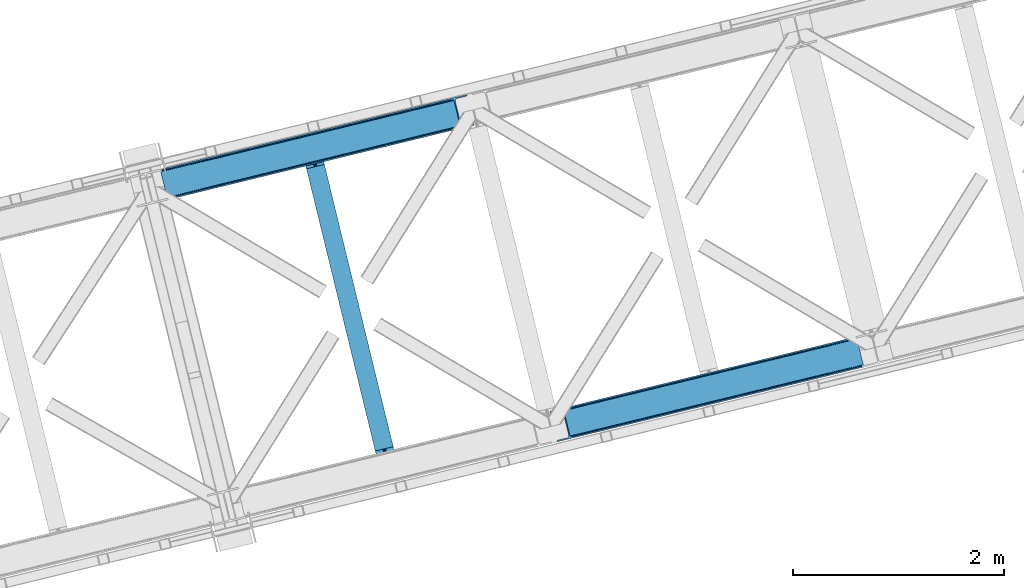
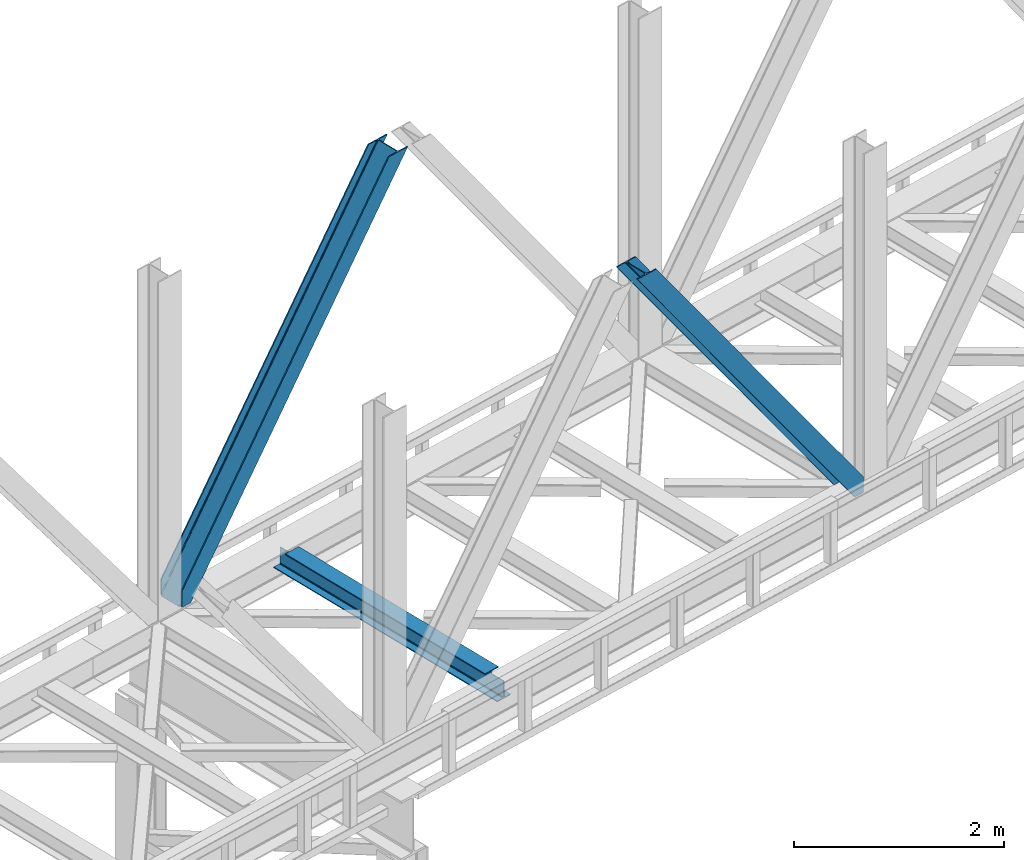
# One storey, part 58 of 93: 2 members, 1 beam.
"""IFC4 building model written with IfcOpenShell, lengths in millimetres."""

from ifc_helpers import new_model, entity, si_unit, converted_unit, derived_unit, direction, frame, origin, place, context, subcontext, project, spatial, triangles, polygons, material, type_object, element, save


model = new_model("IFC4")

# Units and contexts
model_context = context("Model", 3, precision=0.01, world=origin(), true_north=direction((6.12303176911189e-17, 1.0)))
plan_context = context("Plan", 3, precision=0.01, world=origin(), true_north=direction((6.12303176911189e-17, 1.0)))
body_context = subcontext(model_context, "Body", "Model", "MODEL_VIEW")
ifc_project = project(units=[si_unit("LENGTHUNIT", "METRE", prefix="MILLI"), si_unit("AREAUNIT", "SQUARE_METRE"), si_unit("VOLUMEUNIT", "CUBIC_METRE"), converted_unit("PLANEANGLEUNIT", "DEGREE", entity("IfcRatioMeasure", 0.0174532925199433), si_unit("PLANEANGLEUNIT", "RADIAN"), dimensions=[0, 0, 0, 0, 0, 0, 0]), si_unit("MASSUNIT", "GRAM", prefix="KILO"), derived_unit("MASSDENSITYUNIT", [(si_unit("MASSUNIT", "GRAM", prefix="KILO"), 1), (si_unit("LENGTHUNIT", "METRE"), -3)]), derived_unit("MOMENTOFINERTIAUNIT", [(si_unit("LENGTHUNIT", "METRE"), 4)]), si_unit("TIMEUNIT", "SECOND"), si_unit("FREQUENCYUNIT", "HERTZ"), si_unit("THERMODYNAMICTEMPERATUREUNIT", "DEGREE_CELSIUS"), derived_unit("THERMALTRANSMITTANCEUNIT", [(si_unit("MASSUNIT", "GRAM", prefix="KILO"), 1), (si_unit("THERMODYNAMICTEMPERATUREUNIT", "KELVIN"), -1), (si_unit("TIMEUNIT", "SECOND"), -3)]), derived_unit("VOLUMETRICFLOWRATEUNIT", [(si_unit("LENGTHUNIT", "METRE"), 3), (si_unit("TIMEUNIT", "SECOND"), -1)]), derived_unit("MASSFLOWRATEUNIT", [(si_unit("MASSUNIT", "GRAM", prefix="KILO"), 1), (si_unit("TIMEUNIT", "SECOND"), -1)]), derived_unit("ROTATIONALFREQUENCYUNIT", [(si_unit("TIMEUNIT", "SECOND"), -1)]), si_unit("ELECTRICCURRENTUNIT", "AMPERE"), si_unit("ELECTRICVOLTAGEUNIT", "VOLT"), si_unit("POWERUNIT", "WATT"), si_unit("FORCEUNIT", "NEWTON", prefix="KILO"), si_unit("ILLUMINANCEUNIT", "LUX"), si_unit("LUMINOUSFLUXUNIT", "LUMEN"), si_unit("LUMINOUSINTENSITYUNIT", "CANDELA"), derived_unit("USERDEFINED", [(si_unit("MASSUNIT", "GRAM", prefix="KILO"), -1), (si_unit("LENGTHUNIT", "METRE"), -2), (si_unit("TIMEUNIT", "SECOND"), 3), (si_unit("LUMINOUSFLUXUNIT", "LUMEN"), 1)]), derived_unit("LINEARVELOCITYUNIT", [(si_unit("LENGTHUNIT", "METRE"), 1), (si_unit("TIMEUNIT", "SECOND"), -1)]), si_unit("PRESSUREUNIT", "PASCAL"), derived_unit("USERDEFINED", [(si_unit("LENGTHUNIT", "METRE"), -2), (si_unit("MASSUNIT", "GRAM", prefix="KILO"), 1), (si_unit("TIMEUNIT", "SECOND"), -2)]), derived_unit("LINEARFORCEUNIT", [(si_unit("MASSUNIT", "GRAM", prefix="KILO"), 1), (si_unit("LENGTHUNIT", "METRE"), 1), (si_unit("TIMEUNIT", "SECOND"), -2), (si_unit("LENGTHUNIT", "METRE"), -1)]), derived_unit("PLANARFORCEUNIT", [(si_unit("MASSUNIT", "GRAM", prefix="KILO"), 1), (si_unit("LENGTHUNIT", "METRE"), 1), (si_unit("TIMEUNIT", "SECOND"), -2), (si_unit("LENGTHUNIT", "METRE"), -2)])], contexts=[model_context, plan_context])

# Site, building, storey
site_placement = place(None, origin())
site = spatial("IfcSite", under=ifc_project, at=site_placement, CompositionType="ELEMENT")
building_placement = place(site_placement, origin())
building = spatial("IfcBuilding", under=site, at=building_placement, CompositionType="ELEMENT")
storey_placement = place(building_placement, frame((0.0, 0.0, 15900.0)))
storey = spatial("IfcBuildingStorey", under=building, at=storey_placement, CompositionType="ELEMENT", Elevation=15900.0)

# Beam
ifc_material = material(Name="Metal painted (White)")
beam_type = type_object("IfcBeamType", PredefinedType="BEAM")
beam_placement = place(storey_placement, frame((-28709.2553943157, 10788.0005038238, 3441.0)))
element("IfcBeam", 1, at=beam_placement, inside=storey, type_object=beam_type, material=ifc_material, ObjectType="Steel Beam", PredefinedType="BEAM", context=body_context, shape_type="Tessellation", body=[
    polygons([(898.853911352528, 41.4445662733125, 11.000000000004), (898.853911352528, 41.4445662733125, 2.16573425859679e-12), (170.021610174761, 3031.3960252037, 2.16573425859679e-12), (170.021610174761, 3031.3960252037, 11.000000000004), (832.788371398907, 25.3403919499678, 11.000000000004), (103.956070221144, 3015.29185088036, 11.000000000004), (826.839621377614, 23.8903211957417, 12.2179274798217), (98.0073201998513, 3013.84178012613, 12.2179274798217), (821.796514621501, 22.6610105689216, 15.6862915010192), (92.964213443734, 3012.61246949931, 15.6862915010192), (818.42681841833, 21.839611468714, 20.8770650821657), (89.5945172405668, 3011.7910703991, 20.8770650821657), (817.243538468644, 21.5511744621227, 27.0000000000047), (88.4112372908809, 3011.50263339251, 27.0000000000047), (81.6103728838888, 3009.84485074158, 27.0000000000047), (81.6103728838888, 3009.84485074158, 203.000000000006), (88.4112372908809, 3011.50263339251, 203.000000000006), (0.0, 2989.95145893039, 2.16573425859679e-12), (0.0, 2989.95145893039, 10.9999999999997), (66.0655399536216, 3006.05563325373, 11.000000000004), (72.014289974914, 3007.50570400796, 12.2179274798217), (77.057396731027, 3008.73501463478, 15.6862915010192), (80.4270929342029, 3009.55641373498, 20.8770650821657), (817.243538468644, 21.5511744621227, 203.000000000006), (810.442674061652, 19.8933918111876, 203.000000000006), (810.442674061652, 19.8933918111919, 27.0000000000047), (809.259394111966, 19.6049548045984, 20.8770650821657), (805.889697908794, 18.7835557043909, 15.6862915010192), (800.846591152681, 17.5542450775685, 12.2179274798217), (794.897841131389, 16.1041743233447, 11.000000000004), (728.832301177767, 0.0, 10.9999999999997), (728.832301177763, 0.0, 2.16573425859679e-12), (777.543778045854, 184.415062601696, 203.069791966819), (125.8889665066, 2857.75452019162, 203.000000000006), (126.111847295751, 2856.8401777572, 203.617301946336), (126.124761540274, 2856.7871977843, 217.000003693143), (777.398574796925, 185.010597404072, 217.000003676718), (777.399445404814, 185.007025963197, 204.00000679514), (770.833476881408, 182.385463974445, 203.006342981529), (770.610629219866, 183.299815969776, 203.617301946336), (770.597714975342, 183.352795942669, 217.000003693143), (119.323901718691, 2855.1293963229, 217.000003676718), (119.323031110802, 2855.13296776378, 204.00000679514), (119.178731521743, 2855.72494066435, 203.076120467494), (119.088102099608, 2856.09673754069, 203.000000000006), (778.58205952096, 185.298194377518, 223.122939328039), (781.951055929627, 186.122464201395, 228.313710402595), (786.993691333646, 187.353708426699, 231.782072735464), (792.942270204363, 188.804481281383, 232.999999602236), (859.007721069886, 204.909021065317, 232.999999283132), (859.006247733445, 204.91506504219, 243.999994005812), (688.984866829519, 163.4695582453, 243.999994827032), (688.986340165957, 163.463514268427, 233.000000104353), (755.05179103148, 179.568054052361, 232.999999785253), (761.000696159814, 181.017488520584, 231.782072861016), (766.044260666945, 182.244921343721, 228.313710479427), (769.41464757669, 183.06348700115, 223.12293937232), (118.140416994664, 2854.84179934945, 223.122939328039), (114.771420585985, 2854.01752952558, 228.313710402595), (109.728785181961, 2852.78628530027, 231.782072735464), (103.780206311253, 2851.33551244559, 232.999999602236), (37.7147554457299, 2835.23097266166, 232.999999283128), (37.7162287821674, 2835.22492868478, 243.999994005812), (207.737609686093, 2876.67043548167, 243.999994827032), (207.736136349655, 2876.67647945855, 233.000000104357), (141.670685484123, 2860.57193967461, 232.999999785253), (135.721780355798, 2859.12250520639, 231.782072861012), (130.678215848671, 2857.89507238325, 228.313710479427), (127.307828938926, 2857.07650672582, 223.12293937232)], [[[1, 2, 3, 4]], [[5, 1, 4, 6]], [[7, 5, 6, 8]], [[9, 7, 8, 10]], [[11, 9, 10, 12]], [[13, 11, 12, 14]], [[15, 16, 17, 14, 12, 10, 8, 6, 4, 3, 18, 19, 20, 21, 22, 23]], [[13, 24, 25, 26, 27, 28, 29, 30, 31, 32, 2, 1, 5, 7, 9, 11]], [[2, 32, 18, 3]], [[32, 31, 19, 18]], [[31, 30, 20, 19]], [[27, 26, 15, 23]], [[28, 27, 23, 22]], [[29, 28, 22, 21]], [[30, 29, 21, 20]], [[33, 24, 13, 14, 17, 34, 35, 36, 37, 38]], [[25, 39, 40, 41, 42, 43, 44, 16, 15, 26]], [[39, 25, 24, 33]], [[45, 34, 17, 16]], [[41, 40, 38, 37, 46, 47, 48, 49, 50, 51, 52, 53, 54, 55, 56, 57]], [[42, 58, 59, 60, 61, 62, 63, 64, 65, 66, 67, 68, 69, 36, 35, 43]], [[46, 37, 36, 69]], [[47, 46, 69, 68]], [[48, 47, 68, 67]], [[49, 48, 67, 66]], [[50, 49, 66, 65]], [[51, 50, 65, 64]], [[52, 51, 64, 63]], [[53, 52, 63, 62]], [[54, 53, 62, 61]], [[55, 54, 61, 60]], [[56, 55, 60, 59]], [[57, 56, 59, 58]], [[41, 57, 58, 42]]], closed=False),
])

# Members
member_type_1 = type_object("IfcMemberType", PredefinedType="BRACE")
member_1_placement = place(storey_placement, frame((-26366.3673706055, 11039.7075439453, 3694.99929199219)))
element("IfcMember", 2, at=member_1_placement, inside=storey, type_object=member_type_1, ObjectType="Steel Vertical Brace", PredefinedType="BRACE", context=body_context, shape_type="Tessellation", body=[
    triangles([(2966.89099731445, 730.998403930664, 0.80925292968459), (2967.55142211914, 730.014743041993, 1.10690917968532), (2966.07941894531, 729.656625366211, 0.0), (2964.18418579101, 737.428244018554, 0.0), (2962.43312988281, 728.767144775391, 8.31577148437282), (2962.43312988281, 728.767144775391, 0.0), (2505.85634765625, 612.605630493164, 658.855133056641), (2511.35833740234, 609.931375122071, 662.301434326171), (2954.04061889648, 717.839904785156, 38.6743835449197), (2954.16851806641, 719.76304321289, 32.1678039550752), (2501.41243286133, 617.533236694337, 656.552947998047), (2958.54266967773, 726.956790161134, 14.8293273925774), (2955.07311401367, 722.241961669923, 26.1867736816384), (2955.63819580078, 723.795355224609, 22.4381652832017), (655.164660644532, 156.053265380859, 3289.34108276367), (649.437103271484, 156.067218017579, 3285.27854003906), (213.879968261717, 48.4854125976563, 3911.00081176758), (205.268865966795, 47.7970825195316, 3911.00081176758), (643.932788085938, 158.742636108398, 3281.83223876953), (197.318188476562, 49.8748626708984, 3911.00081176758), (639.488873291015, 163.669079589843, 3279.53005371094), (191.239489746094, 54.4036560058594, 3911.00081176758), (636.782061767579, 170.100082397461, 3278.7231262207), (187.958294677734, 60.6939697265625, 3911.00081176758), (2954.15921630859, 716.45859375, 50.6410949707024), (2517.08822021484, 609.917422485352, 666.36397705078), (2051.60733032227, 496.451092529296, 1322.10767211914), (2045.87977294922, 496.465045166016, 1318.04512939453), (1586.12644042969, 382.985925292969, 1977.85369262695), (1580.39888305664, 382.99871520996, 1973.78882446289), (1120.64555053711, 269.519595336915, 2633.59738769531), (1114.91799316406, 269.533547973633, 2629.53251953125), (2040.37545776367, 499.13930053711, 1314.598828125), (1574.89456787109, 385.674133300781, 1970.34484863281), (1109.41367797851, 272.207803344727, 2626.08854370117), (2035.93154296875, 504.066906738281, 1312.29896850586), (1570.45065307617, 390.600576782226, 1968.04266357422), (1104.96976318359, 277.135409545899, 2623.78635864258), (2498.70562133789, 623.963076782227, 655.74602050781), (2033.22473144531, 510.496746826171, 1311.48971557617), (1567.74384155273, 397.031579589844, 1967.23341064453), (1102.26295166016, 283.56524963379, 2622.97710571289), (2909.00383300781, 963.80047302246, 0.0), (2443.52526855469, 850.334143066406, 655.74602050781), (1978.04437866211, 736.868975830079, 1311.48971557617), (1512.56348876953, 623.402645874023, 1967.23341064453), (1047.08259887695, 509.937478637696, 2622.97710571289), (581.601708984374, 396.471148681641, 3278.7231262207), (132.777941894532, 287.066198730468, 3911.00081176758), (307.432397460936, 71.2898345947269, 3911.00081176758), (2954.15921630859, 716.45859375, 182.433050537107), (2954.3522277832, 715.474932861329, 0.0), (2954.16851806641, 719.76304321289, 0.0), (2954.3522277832, 715.474932861329, 182.495837402341), (2955.63819580078, 723.795355224609, 0.0), (2958.54266967773, 726.956790161134, 0.0), (2957.19391479492, 703.816342163085, 182.495837402341), (310.511279296876, 58.6603729248054, 3911.00081176758), (2957.19391479492, 703.816342163085, 0.0), (2846.08906860352, 676.734274291992, 0.0), (69.8631774902351, 0.0, 3911.00081176758), (2843.01018676758, 689.363735961913, 0.0), (66.7842956542954, 12.6294616699215, 3911.00081176758), (160.334399414063, 35.4338836669922, 3911.00081176758), (2936.5626159668, 712.168157958984, 0.0), (2953.95690307617, 734.935372924805, 0.0), (2953.940625, 727.841619873047, 0.0), (177.731011962889, 58.2010986328132, 3911.00081176758), (177.714733886718, 51.1073455810547, 3911.00081176758), (2950.6268737793, 721.023431396485, 0.0), (174.400982666015, 44.2891571044929, 3911.00081176758), (2944.5249206543, 715.519116210937, 0.0), (168.299029541016, 38.7848419189449, 3911.00081176758), (2898.77655029297, 961.307601928711, 0.0), (122.550659179688, 284.573327636719, 3911.00081176758), (2872.85720214844, 973.516159057617, 0.0), (2881.46830444336, 974.204489135742, 0.0), (105.242413330077, 297.47021484375, 3911.00081176758), (96.6289855957039, 296.780722045898, 3911.00081176758), (2889.41898193359, 972.126708984375, 0.0), (113.19309082031, 295.392434692383, 3911.00081176758), (2895.49535522461, 967.597915649414, 0.0), (119.269464111327, 290.863641357422, 3911.00081176758), (3.07888183593604, 273.977462768555, 3911.00081176758), (2779.30477294922, 950.711737060547, 0.0), (2776.22589111328, 963.341198730468, 0.0), (0.0, 286.606924438476, 3911.00081176758), (142.209924316405, 306.482455444337, 3911.00081176758), (150.174554443358, 309.833413696289, 3911.00081176758), (136.107971191406, 300.978140258789, 3911.00081176758), (132.796545410154, 294.159951782227, 3911.00081176758), (240.648101806641, 345.267297363282, 3911.00081176758), (243.726983642577, 332.63783569336, 3911.00081176758), (2887.33073730469, 990.424429321289, 182.495837402341), (2887.33073730469, 990.424429321289, 0.0), (2890.45380249023, 977.805432128906, 182.433050537107), (2890.17242431641, 978.765838623047, 182.495837402341), (1522.42102661133, 644.332763671875, 1977.85369262695), (591.459246826173, 417.401266479492, 3289.34108276367), (1056.94013671875, 530.867596435546, 2633.59738769531), (1987.90191650391, 757.799093627929, 1322.10767211914), (2453.38280639648, 871.264260864258, 666.36397705078), (2890.45380249023, 977.805432128906, 50.6410949707024), (2890.17242431641, 978.765838623047, 0.0), (2890.98400268555, 976.524114990234, 38.6743835449197), (2892.14672241211, 974.998626708984, 33.1630920410134), (2891.98161621094, 974.874215698243, 0.0), (2893.56524047851, 973.137112426757, 26.4425720214822), (2895.14421386719, 971.972067260742, 22.4381652832017), (2903.46463623047, 970.68377380371, 8.31577148437282), (2903.46463623047, 970.68377380371, 0.0), (2899.17652587891, 970.500064086915, 0.0), (2899.17652587891, 970.500064086915, 14.8293273925774), (2895.14421386719, 971.972067260742, 0.0), (2907.11092529297, 971.573254394531, 0.0), (2444.64613037109, 863.708908081055, 658.855133056641), (2442.96716308594, 857.289532470702, 656.552947998047), (2908.44805297851, 970.754699707031, 0.80925292968459), (2908.58060302734, 971.931372070312, 1.10690917968532), (581.045928955078, 403.425375366211, 3279.53005371094), (582.724896240234, 409.845913696288, 3281.83223876953), (586.380487060545, 414.752590942382, 3285.27854003906), (2448.3017211914, 868.615585327148, 662.301434326171), (1977.48859863281, 743.823202514648, 1312.29896850586), (1512.00770874024, 630.356872558594, 1968.04266357422), (1046.52681884765, 516.891705322265, 2623.78635864258), (1979.16524047852, 750.242578125, 1314.598828125), (1513.68435058594, 636.777410888672, 1970.34484863281), (1048.20578613281, 523.311080932617, 2626.08854370117), (1982.82083129883, 755.15041809082, 1318.04512939453), (1517.33994140625, 641.684088134765, 1973.78882446289), (1051.86137695313, 528.218920898438, 2629.53251953125)], [[1, 2, 3], [3, 4, 1], [2, 5, 6], [6, 3, 2], [7, 8, 9], [9, 10, 7], [11, 12, 5], [5, 1, 11], [11, 7, 13], [13, 14, 11], [14, 12, 11], [15, 16, 17], [18, 17, 16], [16, 19, 18], [20, 18, 19], [19, 21, 20], [22, 20, 21], [21, 23, 22], [24, 22, 23], [5, 2, 1], [10, 13, 7], [25, 9, 8], [8, 26, 25], [26, 8, 27], [28, 27, 8], [27, 28, 29], [30, 29, 28], [29, 30, 31], [32, 31, 30], [31, 32, 15], [16, 15, 32], [8, 7, 33], [33, 28, 8], [28, 33, 34], [34, 30, 28], [30, 34, 35], [35, 32, 30], [32, 35, 16], [19, 16, 35], [7, 11, 36], [36, 33, 7], [33, 36, 37], [37, 34, 33], [34, 37, 38], [38, 35, 34], [35, 38, 21], [21, 19, 35], [1, 4, 11], [39, 11, 4], [11, 39, 36], [40, 36, 39], [36, 40, 37], [41, 37, 40], [37, 41, 42], [42, 38, 37], [38, 42, 23], [23, 21, 38], [4, 43, 44], [45, 39, 44], [41, 40, 45], [41, 45, 46], [44, 39, 4], [45, 40, 39], [42, 41, 46], [46, 47, 42], [47, 48, 23], [49, 24, 48], [47, 23, 42], [48, 24, 23], [50, 51, 29], [29, 31, 50], [31, 15, 50], [17, 50, 15], [27, 29, 51], [51, 25, 26], [26, 27, 51], [52, 9, 25], [52, 53, 10], [10, 9, 52], [25, 51, 54], [54, 52, 25], [14, 53, 55], [53, 14, 13], [10, 53, 13], [56, 12, 55], [14, 55, 12], [6, 5, 56], [12, 56, 5], [57, 54, 58], [54, 51, 50], [50, 58, 54], [57, 59, 52], [52, 54, 57], [58, 60, 57], [58, 61, 60], [60, 59, 57], [62, 60, 63], [61, 63, 60], [63, 64, 62], [65, 62, 64], [66, 67, 68], [69, 68, 67], [67, 70, 69], [71, 69, 70], [70, 72, 71], [73, 71, 72], [72, 65, 73], [64, 73, 65], [74, 66, 75], [68, 75, 66], [76, 77, 78], [78, 79, 76], [77, 80, 81], [81, 78, 77], [80, 82, 83], [83, 81, 80], [82, 74, 75], [75, 83, 82], [79, 84, 85], [85, 76, 79], [86, 85, 87], [84, 87, 85], [75, 68, 49], [71, 73, 18], [64, 61, 17], [63, 61, 64], [73, 64, 17], [68, 69, 22], [69, 71, 20], [81, 88, 78], [87, 79, 89], [79, 78, 89], [87, 84, 79], [81, 83, 90], [83, 75, 91], [49, 68, 24], [17, 18, 73], [22, 69, 20], [18, 20, 71], [22, 24, 68], [58, 17, 61], [58, 50, 17], [89, 78, 88], [90, 83, 91], [49, 91, 75], [90, 88, 81], [89, 92, 87], [92, 89, 93], [92, 86, 87], [86, 92, 94], [95, 86, 94], [96, 97, 93], [97, 94, 92], [92, 93, 97], [98, 96, 93], [93, 99, 100], [99, 93, 89], [100, 98, 93], [96, 98, 101], [101, 102, 96], [103, 96, 102], [97, 104, 94], [95, 94, 104], [104, 105, 106], [96, 103, 97], [104, 97, 103], [103, 105, 104], [107, 108, 109], [107, 106, 108], [110, 111, 112], [112, 113, 110], [113, 112, 114], [114, 109, 113], [109, 114, 107], [106, 107, 104], [53, 70, 55], [76, 86, 95], [85, 86, 76], [77, 76, 95], [104, 80, 77], [77, 95, 104], [104, 107, 80], [60, 65, 59], [52, 72, 70], [65, 72, 59], [60, 62, 65], [70, 53, 52], [52, 59, 72], [43, 66, 74], [82, 112, 74], [80, 114, 82], [80, 107, 114], [82, 114, 112], [111, 43, 74], [112, 111, 74], [43, 111, 115], [4, 66, 43], [56, 66, 6], [55, 70, 67], [67, 66, 56], [56, 55, 67], [4, 6, 66], [3, 6, 4], [116, 113, 109], [117, 118, 113], [113, 116, 117], [109, 108, 116], [118, 119, 110], [110, 113, 118], [48, 120, 91], [91, 49, 48], [120, 121, 90], [90, 91, 120], [121, 122, 88], [88, 90, 121], [122, 99, 89], [89, 88, 122], [105, 103, 123], [102, 123, 103], [106, 116, 108], [116, 106, 105], [123, 116, 105], [43, 118, 117], [117, 44, 43], [44, 117, 124], [124, 45, 44], [45, 124, 125], [125, 46, 45], [46, 125, 47], [126, 47, 125], [47, 126, 48], [120, 48, 126], [117, 116, 124], [127, 124, 116], [124, 127, 125], [128, 125, 127], [125, 128, 126], [129, 126, 128], [126, 129, 120], [121, 120, 129], [116, 123, 127], [130, 127, 123], [127, 130, 128], [131, 128, 130], [128, 131, 129], [132, 129, 131], [129, 132, 122], [122, 121, 129], [123, 102, 101], [101, 130, 123], [130, 101, 98], [98, 131, 130], [131, 98, 100], [100, 132, 131], [132, 100, 99], [99, 122, 132], [110, 119, 111], [115, 111, 119], [119, 118, 115], [43, 115, 118]]),
])
member_type_2 = type_object("IfcMemberType", PredefinedType="BRACE")
member_2_placement = place(storey_placement, frame((-30052.8679321289, 13334.379107666, 3694.99929199219)))
element("IfcMember", 3, at=member_2_placement, inside=storey, type_object=member_type_2, ObjectType="Steel Vertical Brace", PredefinedType="BRACE", context=body_context, shape_type="Tessellation", body=[
    triangles([(58.547589111331, 26.625119018554, 0.0), (60.4428222656279, 18.8523376464836, 0.0), (59.1033691406265, 19.6697296142574, 0.80925292968459), (58.9684936523445, 18.4930572509766, 1.10690917968532), (64.0867858886741, 19.7406555175785, 8.31577148437282), (64.0867858886741, 19.7406555175785, 0.0), (522.905291748048, 126.716683959961, 658.855133056641), (68.3748962402351, 19.9243652343739, 14.8293273925774), (72.407208251956, 18.4523620605469, 22.4381652832017), (524.584259033203, 133.136059570312, 656.552947998047), (73.9861816406265, 17.2873168945316, 26.4425720214822), (2834.75487670899, 696.264477539062, 3911.00081176758), (2834.77348022461, 703.359393310546, 3911.00081176758), (2385.94971313477, 593.953280639647, 3278.7231262207), (2386.50781860352, 586.999053955078, 3279.53005371094), (2831.44345092774, 689.447451782225, 3911.00081176758), (2384.82885131836, 580.579678344726, 3281.83223876953), (2825.34149780274, 683.943136596679, 3911.00081176758), (2381.1709350586, 575.671838378907, 3285.27854003906), (2817.37686767578, 680.591015624999, 3911.00081176758), (2376.09217529297, 573.024325561522, 3289.34108276367), (514.170941162112, 119.160168457031, 666.36397705078), (519.247375488281, 121.80884399414, 662.301434326171), (77.0976196289084, 12.6201599121086, 50.6410949707024), (76.5650939941406, 13.9003143310547, 38.6743835449197), (75.4046997070327, 15.4258026123043, 33.1630920410134), (524.028479003908, 140.090286254883, 655.74602050781), (990.065148925783, 246.601226806641, 1312.29896850586), (989.509368896488, 253.556616210937, 1311.48971557617), (1455.54603881836, 360.067556762695, 1968.04266357422), (1454.99025878906, 367.021783447266, 1967.23341064453), (1921.02692871094, 473.533886718749, 2623.78635864258), (1920.47114868164, 480.48811340332, 2622.97710571289), (988.386181640628, 240.181851196288, 1314.598828125), (1453.8670715332, 353.648181152343, 1970.34484863281), (1919.34796142578, 467.113348388672, 2626.08854370117), (984.728265380862, 235.274011230469, 1318.04512939453), (1450.20915527344, 348.740341186523, 1973.78882446289), (1915.69004516602, 462.20550842285, 2629.53251953125), (979.651831054689, 232.626498413085, 1322.10767211914), (1445.13272094727, 346.092828369141, 1977.85369262695), (1910.61361083985, 459.557995605468, 2633.59738769531), (77.0976196289084, 12.6201599121086, 182.433050537107), (2723.82443847656, 657.786593627929, 3911.00081176758), (75.5674804687515, 15.5502136230461, 0.0), (77.381323242189, 11.6585906982418, 0.0), (77.381323242189, 11.6585906982418, 182.495837402341), (68.3748962402351, 19.9243652343739, 0.0), (72.407208251956, 18.4523620605469, 0.0), (2726.9033203125, 645.157131958007, 3911.00081176758), (80.223010253907, 0.0, 182.495837402341), (80.223010253907, 0.0, 0.0), (191.327856445314, 27.0832305908207, 0.0), (2967.5537475586, 703.817504882813, 3911.00081176758), (1399.80990600586, 593.394012451172, 1967.23341064453), (2779.59312744141, 929.730459594726, 3911.00081176758), (2330.76936035157, 820.325509643555, 3278.7231262207), (1865.29079589844, 706.859179687499, 2622.97710571289), (934.329016113283, 479.927682495118, 1311.48971557617), (468.848126220706, 366.462515258789, 655.74602050781), (3.36723632812573, 252.996185302734, 0.0), (2964.47486572266, 716.448129272461, 3911.00081176758), (188.248974609378, 39.7138549804677, 0.0), (2870.92243652344, 693.643707275391, 3911.00081176758), (94.6965454101592, 16.9094329833988, 0.0), (2862.31133422852, 692.954214477539, 3911.00081176758), (86.083117675782, 16.2199401855469, 0.0), (2854.35833129883, 695.031994628906, 3911.00081176758), (78.1324401855491, 18.2977203369137, 0.0), (2848.27963256836, 699.560787963866, 3911.00081176758), (72.0537414550781, 22.8265136718746, 0.0), (2845.00076293946, 705.852264404297, 3911.00081176758), (68.7725463867209, 29.1168273925778, 0.0), (2789.82041015625, 932.223330688475, 3911.00081176758), (13.5921936035156, 255.489056396484, 0.0), (2789.83668823242, 939.318246459961, 3911.00081176758), (13.6107971191414, 262.582809448242, 0.0), (2793.14811401367, 946.135272216796, 3911.00081176758), (16.9222229003935, 269.400997924804, 0.0), (2799.25239257813, 951.639587402344, 3911.00081176758), (23.0241760253921, 274.904150390625, 0.0), (2807.21469726563, 954.990545654297, 3911.00081176758), (30.9888061523452, 278.256271362305, 0.0), (2900.76712646485, 977.794967651367, 3911.00081176758), (124.541235351564, 301.060693359375, 0.0), (2897.68824462891, 990.425592041016, 3911.00081176758), (121.462353515628, 313.691317749022, 0.0), (2770.23555908203, 940.54956665039, 3911.00081176758), (2762.2848815918, 942.628509521484, 3911.00081176758), (2657.04014282227, 931.765219116211, 3911.00081176758), (2753.67145385742, 941.939016723632, 3911.00081176758), (2660.1190246582, 919.134594726562, 3911.00081176758), (2776.31193237305, 936.020773315429, 3911.00081176758), (10.3575073242209, 286.608087158203, 182.495837402341), (10.3575073242209, 286.608087158203, 0.0), (13.2015197753935, 274.94949645996, 182.495837402341), (13.3922058105491, 273.966998291015, 182.433050537107), (1381.42498168946, 607.439666748047, 1977.85369262695), (1846.90587158203, 720.905996704101, 2633.59738769531), (2312.38676147461, 834.37116394043, 3289.34108276367), (915.944091796879, 493.973336791993, 1322.10767211914), (13.3922058105491, 273.966998291015, 50.6410949707024), (450.465527343753, 380.508169555664, 666.36397705078), (13.2015197753935, 274.94949645996, 0.0), (13.5084777832053, 272.584524536132, 38.6743835449197), (13.3829040527344, 270.661386108399, 0.0), (13.3829040527344, 270.661386108399, 32.1678039550752), (12.4783081054702, 268.183630371093, 26.1867736816384), (11.9109008789092, 266.62907409668, 22.4381652832017), (11.9109008789092, 266.62907409668, 0.0), (9.00875244140843, 263.467639160155, 14.8293273925774), (9.00875244140843, 263.467639160155, 0.0), (5.115966796875, 261.657284545898, 8.31577148437282), (5.115966796875, 261.657284545898, 0.0), (1.47200317382885, 260.768966674805, 0.0), (461.697399902347, 377.819961547852, 658.855133056641), (456.190759277346, 380.493054199218, 662.301434326171), (466.141314697266, 372.892355346679, 656.552947998047), (0.660424804689683, 259.42718811035, 0.80925292968459), (0.0, 260.409686279296, 1.10690917968532), (2318.11431884766, 834.35721130371, 3285.27854003906), (2323.61863403321, 831.682955932616, 3281.83223876953), (2328.06254882813, 826.755349731446, 3279.53005371094), (921.671649169923, 493.959384155272, 1318.04512939453), (1387.1525390625, 607.424551391601, 1973.78882446289), (1852.63342895508, 720.890881347656, 2629.53251953125), (927.178289794923, 491.285128784179, 1314.598828125), (1392.6591796875, 604.751458740235, 1970.34484863281), (1858.13774414063, 718.216625976562, 2626.08854370117), (931.622204589847, 486.358685302734, 1312.29896850586), (1397.10309448242, 599.823852539063, 1968.04266357422), (1862.583984375, 713.290182495117, 2623.78635864258)], [[1, 2, 3], [4, 3, 2], [5, 4, 6], [2, 6, 4], [7, 8, 9], [10, 3, 8], [8, 7, 10], [9, 11, 7], [3, 4, 5], [5, 8, 3], [12, 13, 14], [14, 15, 12], [16, 12, 15], [15, 17, 16], [18, 16, 17], [17, 19, 18], [20, 18, 19], [19, 21, 20], [22, 23, 24], [25, 24, 23], [25, 7, 26], [25, 23, 7], [11, 26, 7], [10, 27, 1], [1, 3, 10], [28, 29, 27], [27, 10, 28], [30, 31, 28], [29, 28, 31], [32, 33, 31], [31, 30, 32], [15, 14, 33], [33, 32, 15], [34, 28, 10], [10, 7, 34], [35, 30, 28], [28, 34, 35], [36, 32, 35], [30, 35, 32], [17, 15, 36], [32, 36, 15], [37, 34, 23], [7, 23, 34], [38, 35, 37], [34, 37, 35], [39, 36, 38], [35, 38, 36], [19, 17, 36], [36, 39, 19], [40, 37, 22], [23, 22, 37], [41, 38, 40], [37, 40, 38], [42, 39, 41], [38, 41, 39], [21, 19, 42], [39, 42, 19], [41, 43, 44], [44, 21, 42], [21, 44, 20], [42, 41, 44], [43, 41, 40], [40, 22, 43], [24, 43, 22], [45, 11, 9], [45, 26, 11], [46, 25, 26], [46, 47, 24], [43, 24, 47], [24, 25, 46], [26, 45, 46], [48, 8, 5], [5, 6, 48], [49, 9, 8], [8, 48, 49], [9, 49, 45], [47, 44, 43], [50, 47, 51], [47, 50, 44], [52, 51, 46], [47, 46, 51], [50, 53, 54], [53, 50, 51], [52, 53, 51], [33, 55, 31], [13, 56, 57], [58, 14, 57], [55, 33, 58], [57, 14, 13], [58, 33, 14], [31, 59, 29], [59, 60, 27], [59, 31, 55], [61, 1, 60], [59, 27, 29], [60, 1, 27], [62, 54, 53], [53, 63, 62], [64, 62, 63], [63, 65, 64], [66, 64, 65], [65, 67, 66], [68, 66, 67], [67, 69, 68], [70, 68, 69], [69, 71, 70], [72, 70, 71], [71, 73, 72], [74, 72, 75], [73, 75, 72], [76, 74, 77], [75, 77, 74], [78, 76, 79], [77, 79, 76], [80, 78, 81], [79, 81, 78], [82, 80, 83], [81, 83, 80], [84, 82, 85], [83, 85, 82], [86, 84, 85], [85, 87, 86], [56, 13, 74], [16, 18, 66], [20, 50, 54], [44, 50, 20], [18, 20, 64], [13, 12, 70], [12, 16, 68], [88, 80, 89], [90, 91, 86], [91, 89, 82], [90, 92, 91], [88, 93, 78], [93, 56, 76], [74, 13, 72], [64, 66, 18], [70, 12, 68], [66, 68, 16], [70, 72, 13], [54, 64, 20], [54, 62, 64], [82, 89, 80], [78, 93, 76], [74, 76, 56], [78, 80, 88], [82, 86, 91], [86, 82, 84], [90, 87, 94], [90, 86, 87], [87, 95, 94], [96, 90, 94], [92, 96, 97], [96, 92, 90], [92, 97, 98], [98, 99, 92], [99, 100, 92], [91, 92, 100], [101, 98, 97], [97, 102, 103], [103, 101, 97], [104, 96, 94], [94, 95, 104], [104, 105, 102], [104, 106, 107], [107, 105, 104], [96, 104, 102], [102, 97, 96], [108, 106, 109], [108, 107, 106], [110, 109, 106], [109, 110, 111], [112, 111, 110], [111, 112, 113], [114, 113, 112], [75, 73, 61], [114, 75, 61], [114, 112, 75], [114, 61, 115], [79, 77, 110], [77, 75, 112], [106, 79, 110], [110, 77, 112], [73, 1, 61], [6, 73, 48], [1, 6, 2], [1, 73, 6], [48, 71, 49], [49, 71, 69], [73, 71, 48], [45, 49, 69], [104, 81, 79], [79, 106, 104], [95, 81, 104], [83, 95, 87], [87, 85, 83], [83, 81, 95], [45, 69, 46], [52, 67, 65], [46, 69, 67], [52, 46, 67], [65, 53, 52], [53, 65, 63], [116, 117, 105], [105, 107, 116], [118, 111, 113], [113, 119, 118], [118, 116, 108], [108, 109, 118], [109, 111, 118], [113, 120, 119], [107, 108, 116], [117, 103, 102], [102, 105, 117], [89, 91, 121], [100, 121, 91], [88, 89, 122], [121, 122, 89], [93, 88, 123], [122, 123, 88], [56, 93, 57], [123, 57, 93], [124, 101, 103], [103, 117, 124], [125, 98, 101], [101, 124, 125], [126, 99, 98], [98, 125, 126], [121, 100, 126], [99, 126, 100], [127, 124, 116], [117, 116, 124], [128, 125, 124], [124, 127, 128], [129, 126, 128], [125, 128, 126], [122, 121, 129], [126, 129, 121], [130, 127, 118], [116, 118, 127], [131, 128, 130], [127, 130, 128], [132, 129, 128], [128, 131, 132], [123, 122, 129], [129, 132, 123], [60, 118, 61], [119, 61, 118], [59, 130, 60], [118, 60, 130], [55, 131, 130], [130, 59, 55], [58, 132, 55], [131, 55, 132], [57, 123, 58], [132, 58, 123], [120, 113, 114], [114, 115, 120], [115, 61, 119], [119, 120, 115]]),
])

save(model, "model.ifc")
